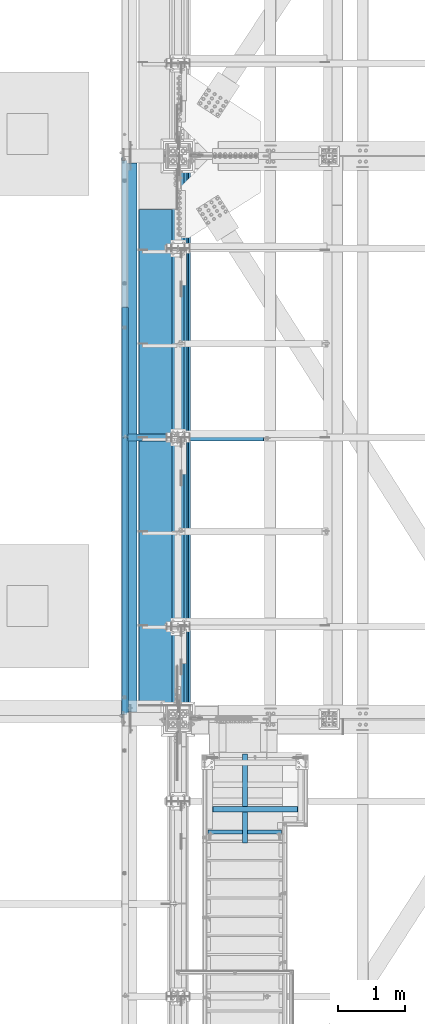
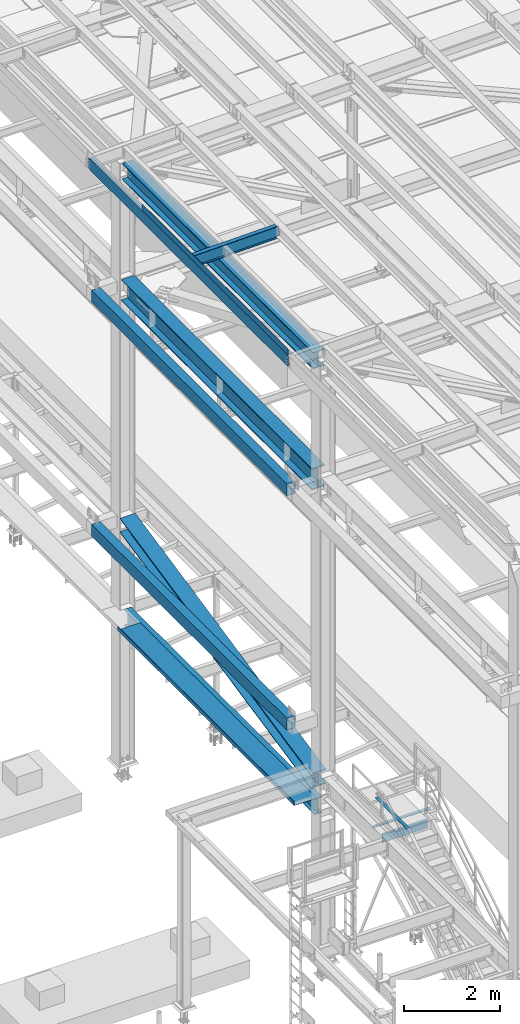
# One storey, part 1804 of 3843: 12 beams, 1 member, 11 elements without a shape of their own.
"""IFC2X3 building model written with IfcOpenShell, lengths in millimetres."""

from ifc_helpers import new_model, si_unit, frame, origin_with_axes, place, context, subcontext, project, spatial, faceted_brep, material, type_object, element, aggregate, save


model = new_model("IFC2X3")

# Units and contexts
model_context = context("Model", 3, precision=1e-05, world=origin_with_axes())
body_context = subcontext(model_context, "Body", "Model", "MODEL_VIEW")
ifc_project = project(units=[si_unit("LENGTHUNIT", "METRE", prefix="MILLI"), si_unit("AREAUNIT", "SQUARE_METRE"), si_unit("VOLUMEUNIT", "CUBIC_METRE"), si_unit("MASSUNIT", "GRAM", prefix="KILO"), si_unit("TIMEUNIT", "SECOND"), si_unit("PLANEANGLEUNIT", "RADIAN"), si_unit("SOLIDANGLEUNIT", "STERADIAN"), si_unit("THERMODYNAMICTEMPERATUREUNIT", "DEGREE_CELSIUS"), si_unit("LUMINOUSINTENSITYUNIT", "LUMEN")], contexts=[model_context])

# Site, building, storey
site_placement = place(None, origin_with_axes())
site = spatial("IfcSite", under=ifc_project, at=site_placement, CompositionType="ELEMENT")
building_placement = place(site_placement, origin_with_axes())
building = spatial("IfcBuilding", under=site, at=building_placement, Name="Undefined", CompositionType="ELEMENT")
storey_placement = place(building_placement, origin_with_axes())
storey = spatial("IfcBuildingStorey", under=building, at=storey_placement, Name="Undefined", CompositionType="ELEMENT", Elevation=0.0)

# Assembly, beams
assembly_1_placement = place(storey_placement, origin_with_axes())
assembly_1 = element("IfcElementAssembly", 1, at=assembly_1_placement, inside=storey, Name="BEAM", AssemblyPlace="NOTDEFINED", PredefinedType="RIGID_FRAME")
ifc_material_1 = material(Name="STEEL/A572-50")
beam_type_1 = type_object("IfcBeamType", Name="C12X20.7", PredefinedType="NOTDEFINED")
beam_1_placement = place(assembly_1_placement, frame((35779.1150555287, 33845.4999999999, 45560.3009647407), z_axis=(-0.0211520980073474, 0.0, 0.999776269347241), x_axis=(0.0, 1.0, 0.0)))
beam_1 = element("IfcBeam", 2, at=beam_1_placement, type_object=beam_type_1, material=ifc_material_1, Name="BEAM", ObjectType="C12X20.7", context=body_context, shape_type="Brep", body=[
    faceted_brep([(15.8750000000582, 30.1624999998166, -126.999999999382), (15.8750003662499, 38.1000000000058, -127.000000023749), (53.975000190796, 38.0999999998094, -126.999999999396), (53.975000190796, 30.1624999998166, -126.999999999382), (58.8350797088351, 38.0999999998094, -127.96672992198), (58.8350797088351, 30.1624999998166, -127.966729921965), (62.955256176996, 38.0999999998021, -130.719743822439), (62.955256176996, 30.1624999998166, -130.719743822439), (65.7082700774772, 38.0999999997948, -134.839920290578), (65.7082700774772, 30.1624999998094, -134.6749274998), (66.6750000000611, 1.14757131086662e-06, -139.699999808552), (66.6750000000611, 38.0999999997948, -139.699999808603), (66.6750000000611, 38.0999999997803, -152.399999999783), (66.6750000000611, -38.1000000000931, -152.39999999971), (66.6750000000611, -38.1000000000931, -146.047459999718), (8289.92500000005, -38.0999999997948, 146.047459999805), (8289.92500000005, -38.0999999997875, 152.399999999798), (66.6750000000611, -38.0999999997875, 152.399999999798), (66.6750000000611, -38.0999999997948, 146.047459999805), (8289.92500000005, 38.1000000000859, 152.399999999725), (66.6750000000611, 38.1000000000859, 152.399999999725), (53.975000190796, 30.1625000000713, 126.999999999265), (53.975000190796, 38.100000000064, 126.999999999258), (15.8750006201954, 38.1000000000058, 126.999999975014), (15.8750000000582, 30.1625000000713, 126.999999999265), (58.8350797088351, 30.1625000000786, 127.966729921849), (58.8350797088351, 38.100000000064, 127.966729921842), (62.955256176996, 30.1625000000786, 130.719743822316), (62.955256176996, 38.1000000000568, 130.719743822301), (65.7082700774772, 30.1625000000786, 134.674927499756), (65.7082700774772, 38.1000000000713, 134.83992029044), (66.6750000000611, 1.1482770787552e-06, 139.699999808494), (66.6750000000611, 38.1000000000713, 139.699999808465), (8290.89172992263, 30.1625000000786, 134.674927499756), (8289.92500000005, 1.1482770787552e-06, 139.699999808494), (8289.92500000005, 38.1000000000713, 139.699999808465), (8290.89172992263, 38.1000000000713, 134.83992029044), (8293.64474382311, 30.1625000000786, 130.719743822316), (8293.64474382311, 38.1000000000568, 130.719743822301), (8297.76492029126, 30.1625000000786, 127.966729921849), (8297.76492029126, 38.100000000064, 127.966729921842), (8302.62499980931, 30.1625000000713, 126.999999999265), (8302.62499980931, 38.100000000064, 126.999999999258), (8340.72500000005, 30.1625000000713, 126.999999999265), (8340.72500000005, 38.100000000064, 126.999999999258), (8340.72500000005, 30.162500000064, 114.299999983516), (8340.72500000005, 30.1624999998385, -116.300000010502), (8340.72500000005, 30.1624999998166, -126.999999999382), (8340.72500000005, 38.0999999998094, -126.999999999396), (8302.62499980931, 30.1624999998166, -126.999999999382), (8302.62499980931, 38.0999999998094, -126.999999999396), (8297.76492029126, 30.1624999998166, -127.966729921965), (8297.76492029126, 38.0999999998094, -127.96672992198), (8293.64474382311, 30.1624999998166, -130.719743822439), (8293.64474382311, 38.0999999998021, -130.719743822439), (8290.89172992263, 30.1624999998094, -134.6749274998), (8290.89172992263, 38.0999999997948, -134.839920290578), (8289.92500000005, 1.14757131086662e-06, -139.699999808552), (8289.92500000005, 38.0999999997948, -139.699999808603), (8289.92500000005, -38.1000000000931, -146.047459999718), (8289.92500000005, -38.1000000000931, -152.39999999971), (8289.92500000005, 38.0999999997803, -152.399999999783), (15.8750000000582, 30.1624999998312, -116.299999999967), (15.8750000000582, 30.1625000000568, 114.299999994066)], [[[0, 1, 2, 3]], [[3, 2, 4, 5]], [[5, 4, 6, 7]], [[7, 6, 8, 9]], [[10, 11, 12, 13, 14]], [[9, 8, 11, 10]], [[15, 16, 17, 18]], [[16, 19, 20, 17]], [[21, 22, 23, 24]], [[25, 26, 22, 21]], [[27, 28, 26, 25]], [[29, 30, 28, 27]], [[31, 32, 30, 29]], [[17, 20, 32, 31, 18]], [[29, 33, 34, 15, 18, 31]], [[16, 15, 34, 35, 19]], [[33, 36, 35, 34]], [[37, 38, 36, 33]], [[39, 40, 38, 37]], [[41, 42, 40, 39]], [[43, 44, 42, 41]], [[44, 43, 45, 46, 47, 48]], [[47, 49, 50, 48]], [[51, 52, 50, 49]], [[53, 54, 52, 51]], [[55, 56, 54, 53]], [[57, 58, 56, 55]], [[59, 60, 61, 58, 57]], [[60, 59, 14, 13]], [[61, 60, 13, 12]], [[6, 4, 2, 1, 23, 22, 26, 28, 30, 32, 20, 19, 35, 36, 38, 40, 42, 44, 48, 50, 52, 54, 56, 58, 61, 12, 11, 8]], [[62, 63, 24, 23, 1, 0]], [[55, 53, 51, 49, 47, 46, 45, 43, 41, 39, 37, 33, 29, 27, 25, 21, 24, 63, 62, 0, 3, 5, 7, 9]], [[59, 57, 55, 9, 10, 14]]]),
])
ifc_material_2 = material(Name="STEEL/A36")
beam_type_2 = type_object("IfcBeamType", PredefinedType="NOTDEFINED")
beam_2_placement = place(assembly_1_placement, frame((35839.3101109824, 36909.3750000001, 45717.1843160671), z_axis=(0.0, -1.0, 0.0), x_axis=(-0.999776270257024, 0.0, -0.0211520550054595)))
beam_2 = element("IfcBeam", 3, at=beam_2_placement, type_object=beam_type_2, material=ifc_material_2, Name="BENT_PLATE", context=body_context, shape_type="Brep", body=[
    faceted_brep([(-3.50355549016967e-07, -3.17499999742722, -3048.00000001723), (3.50421032635495e-07, -3.17500000260043, 3048.00000001724), (3.5035191103816e-07, 3.17499999739084, 3048.00000001724), (-3.50424670614302e-07, 3.17500000256405, -3048.00000001723), (101.599999864371, 3.17499999856227, 3048.00000000522), (101.599998739839, 3.17500000373548, -3048.00000002925), (95.249998765099, -3.17499999632128, -3048.00000002851), (95.2499998896274, -3.17500000149448, 3048.00000000597), (101.600000309205, -161.925000875126, 3047.9999999938), (101.599999608374, -161.925000446165, -3048.00000004067), (95.2500003092064, -161.925000900388, 3047.99999999456), (95.2499996083752, -161.925000471427, -3048.00000003992)], [[[0, 1, 2, 3]], [[3, 2, 4, 5]], [[1, 0, 6, 7]], [[5, 4, 8, 9]], [[4, 2, 1, 7, 10, 8]], [[7, 6, 11, 10]], [[6, 0, 3, 5, 9, 11]], [[10, 11, 9, 8]]]),
])
aggregate(assembly_1, [beam_2, beam_1])

# Assembly, beam
assembly_2_placement = place(storey_placement, origin_with_axes())
assembly_2 = element("IfcElementAssembly", 4, at=assembly_2_placement, inside=storey, Name="STAIR", AssemblyPlace="NOTDEFINED", PredefinedType="RIGID_FRAME")
beam_type_3 = type_object("IfcBeamType", Name="L3X3X1/4", PredefinedType="NOTDEFINED")
beam_3_placement = place(assembly_2_placement, frame((37014.1499998894, 32507.7666666667, 34048.7000000047), z_axis=(0.0, -1.0, 0.0), x_axis=(1.0, 0.0, 0.0)))
beam_3 = element("IfcBeam", 5, at=beam_3_placement, type_object=beam_type_3, material=ifc_material_2, Name="ANGLE", ObjectType="L3X3X1/4", context=body_context, shape_type="Brep", body=[
    faceted_brep([(1339.8500002734, 31.75, 38.0999999999985), (1339.8500002734, 31.75, -31.75), (1339.8500002734, 31.7499999999927, -38.0999999999985), (1333.5000002728, 38.0999999999985, -38.0999999999985), (1333.5000002728, 38.0999999999985, 38.0999999999985), (1397.0000002734, 31.75, -31.75), (1397.0000002734, 31.7499999999927, -38.0999999999985), (1409.7000002734, 19.0499999999884, -31.75), (1409.70000020599, 19.0499999999884, -38.0999999999985), (76.2000000006228, 38.0999999999985, 38.0999999999985), (76.2000000006228, 38.0999999999985, -38.0999999999985), (69.8500000000349, 31.7499999999927, -38.0999999999985), (69.8500000000349, 31.75, -31.75), (69.8500000000349, 31.75, 38.0999999999985), (12.7000000000262, 31.7499999999927, -38.0999999999985), (12.7000000000262, 31.75, -31.75), (0.0, 19.0499999999884, -38.0999999999985), (0.0, 19.0500000000029, -31.75), (0.0, -38.0999999999985, -38.0999999999985), (0.0, -38.0999999999985, -31.75), (1409.70000020599, -38.0999999999985, -38.0999999999985), (1409.70000020599, -38.0999999999985, -31.75)], [[[0, 1, 2, 3, 4]], [[5, 6, 2, 1]], [[7, 8, 6, 5]], [[9, 10, 11, 12, 13]], [[12, 11, 14, 15]], [[15, 14, 16, 17]], [[18, 19, 17, 16]], [[19, 18, 20, 21]], [[1, 12, 15, 17, 19, 21, 7, 5]], [[13, 12, 1, 0]], [[9, 13, 0, 4]], [[10, 9, 4, 3]], [[20, 18, 16, 14, 11, 10, 3, 2, 6, 8]], [[21, 20, 8, 7]]]),
])
aggregate(assembly_2, [beam_3])

# Assembly, member
assembly_3_placement = place(storey_placement, origin_with_axes())
assembly_3 = element("IfcElementAssembly", 6, at=assembly_3_placement, inside=storey, Name="ref.", AssemblyPlace="NOTDEFINED", PredefinedType="RIGID_FRAME")
ifc_material_3 = material(Name="STEEL/Steel_Undefined")
member_type = type_object("IfcMemberType", PredefinedType="NOTDEFINED")
member_placement = place(assembly_3_placement, frame((37566.5999999524, 32009.4314299331, 34134.425), z_axis=(-1.0, 0.0, 0.0), x_axis=(0.0, 1.0, 0.0)))
member = element("IfcMember", 7, at=member_placement, type_object=member_type, material=ifc_material_3, Name="ref.", context=body_context, shape_type="Brep", body=[
    faceted_brep([(0.0, 3.17500000000291, -38.0999999999985), (0.0, 3.17500000000291, 38.0999999999985), (1320.8, 3.17500000000291, 38.0999999999985), (1320.8, 3.17500000000291, -38.0999999999985), (0.0, -3.17500000000291, 38.0999999999985), (1320.8, -3.17500000000291, 38.0999999999985), (0.0, -3.17500000000291, -38.0999999999985), (1320.8, -3.17500000000291, -38.0999999999985)], [[[0, 1, 2, 3]], [[1, 4, 5, 2]], [[4, 6, 7, 5]], [[6, 0, 3, 7]], [[5, 7, 3, 2]], [[6, 4, 1, 0]]]),
])
aggregate(assembly_3, [member])

# Assembly, beam
assembly_4_placement = place(storey_placement, origin_with_axes())
assembly_4 = element("IfcElementAssembly", 8, at=assembly_4_placement, inside=storey, Name="BEAM", AssemblyPlace="NOTDEFINED", PredefinedType="RIGID_FRAME")
beam_type_4 = type_object("IfcBeamType", Name="C8X11.5", PredefinedType="NOTDEFINED")
beam_4_placement = place(assembly_4_placement, frame((38125.3999999478, 32172.275, 33985.2000000051), z_axis=(0.0, 0.0, 1.0), x_axis=(-1.0, 0.0, 0.0)))
beam_4 = element("IfcBeam", 9, at=beam_4_placement, type_object=beam_type_4, material=ifc_material_2, Name="BEAM", ObjectType="C8X11.5", context=body_context, shape_type="Brep", body=[
    faceted_brep([(12.6999999477412, 28.5749999999971, -101.599999999999), (12.6999999477412, 28.5749999999971, 101.599999999999), (1104.90000001137, 28.5749999999971, 101.599999999999), (1104.90000001137, 28.5749999999971, -101.599999999999), (12.6999999477412, -28.5749999999971, 101.599999999999), (1104.90000001137, -28.5749999999971, 101.599999999999), (12.6999999477412, -28.5749999999971, 96.8355949999968), (1104.90000001137, -28.5749999999971, 96.8355949999968), (12.6999999477412, 22.2249999999985, 88.3723150000005), (1104.90000001137, 22.2249999999985, 88.3723150000005), (12.6999999477412, 22.2249999999985, -88.3723150000005), (1104.90000001137, 22.2249999999985, -88.3723150000005), (12.6999999477412, -28.5749999999971, -96.8355949999968), (1104.90000001137, -28.5749999999971, -96.8355949999968), (12.6999999477412, -28.5749999999971, -101.599999999999), (1104.90000001137, -28.5749999999971, -101.599999999999)], [[[0, 1, 2, 3]], [[1, 4, 5, 2]], [[4, 6, 7, 5]], [[6, 8, 9, 7]], [[8, 10, 11, 9]], [[10, 12, 13, 11]], [[12, 14, 15, 13]], [[14, 0, 3, 15]], [[5, 7, 9, 11, 13, 15, 3, 2]], [[14, 12, 10, 8, 6, 4, 1, 0]]]),
])
aggregate(assembly_4, [beam_4])

assembly_5_placement = place(storey_placement, origin_with_axes())
assembly_5 = element("IfcElementAssembly", 10, at=assembly_5_placement, inside=storey, Name="BEAM", AssemblyPlace="NOTDEFINED", PredefinedType="RIGID_FRAME")
ifc_material_4 = material(Name="STEEL/A992")
beam_type_5 = type_object("IfcBeamType", Name="W21X101", PredefinedType="NOTDEFINED")
beam_5_placement = place(assembly_5_placement, frame((36576.0, 33845.5, 42197.3375), z_axis=(0.0, 0.0, 1.0), x_axis=(0.0, 1.0, 0.0)))
beam_5 = element("IfcBeam", 11, at=beam_5_placement, type_object=beam_type_5, material=ifc_material_4, Name="BEAM", ObjectType="W21X101", context=body_context, shape_type="Brep", body=[
    faceted_brep([(8161.33749999999, -155.574999999997, 250.824999999997), (8161.33749999999, -6.34999999999854, 250.824999999997), (8161.33749999999, 6.34999999999854, 250.824999999997), (8161.33749999999, 155.574999999997, 250.824999999997), (8149.42289888391, 155.574999999997, 271.462500000001), (8149.42289888391, -155.574999999997, 271.462500000001), (198.4375, -6.34999999999854, -250.824999999997), (198.4375, -155.574999999997, -250.824999999997), (8158.16250000001, -155.574999999997, -250.824999999997), (8158.16250000001, -6.34999999999854, -250.824999999997), (198.4375, -155.574999999997, -271.462500000001), (8158.16250000001, -155.574999999997, -271.462500000001), (198.4375, 155.574999999997, -271.462500000001), (8158.16250000001, 155.574999999997, -271.462500000001), (198.4375, 155.574999999997, -250.824999999997), (198.4375, 6.34999999999854, -250.824999999997), (8158.16250000001, 6.34999999999854, -250.824999999997), (8158.16250000001, 155.574999999997, -250.824999999997), (198.4375, -6.34999999999854, 250.824999999997), (198.4375, -155.574999999997, 250.824999999997), (198.4375, -155.574999999997, 271.462500000001), (198.4375, 155.574999999997, 271.462500000001), (198.4375, 155.574999999997, 250.824999999997), (198.4375, 6.34999999999854, 250.824999999997), (8161.33749999999, -6.34999999999854, 250.428), (8161.33749999999, 6.34999999999854, 250.428), (8126.41250000001, -6.34999999999854, 250.428), (8126.41250000001, 6.34999999999854, 250.428), (8081.02759456493, -6.34999999999854, 234.406795689014), (8081.02759456493, 6.34999999999854, 234.406795689014), (8076.73823210121, -6.34999999999854, 231.347328818971), (8076.73823210121, 6.34999999999854, 231.347328818971), (8074.73137781811, -6.34999999999854, 226.475829690324), (8074.73137781811, 6.34999999999854, 226.475829690324), (8075.62106119224, -6.34999999999854, 221.282812131351), (8075.62106119224, 6.34999999999854, 221.282812131351), (8079.13506922779, -6.34999999999854, 217.357163726287), (8079.13506922779, 6.34999999999854, 217.357163726287), (8084.19823441855, -6.34999999999854, 215.900000000001), (8084.19823441855, 6.34999999999854, 215.900000000001), (8158.16250000001, -6.34999999999854, 215.900000000001), (8158.16250000001, 6.34999999999854, 215.900000000001)], [[[0, 1, 2, 3, 4, 5]], [[6, 7, 8, 9]], [[7, 10, 11, 8]], [[10, 12, 13, 11]], [[14, 15, 16, 17]], [[12, 14, 17, 13]], [[10, 7, 6, 18, 19, 20, 21, 22, 23, 15, 14, 12]], [[20, 19, 0, 5]], [[21, 20, 5, 4]], [[22, 21, 4, 3]], [[23, 22, 3, 2]], [[24, 25, 2, 1]], [[26, 27, 25, 24]], [[28, 29, 27, 26]], [[30, 31, 29, 28]], [[32, 33, 31, 30]], [[34, 35, 33, 32]], [[36, 37, 35, 34]], [[38, 39, 37, 36]], [[39, 38, 40, 41]], [[15, 23, 2, 25, 27, 29, 31, 33, 35, 37, 39, 41, 16]], [[40, 9, 8, 11, 13, 17, 16, 41]], [[38, 36, 34, 32, 30, 28, 26, 24, 1, 18, 6, 9, 40]], [[19, 18, 1, 0]]]),
])
aggregate(assembly_5, [beam_5])

assembly_6_placement = place(storey_placement, origin_with_axes())
assembly_6 = element("IfcElementAssembly", 12, at=assembly_6_placement, inside=storey, Name="GIRT", AssemblyPlace="NOTDEFINED", PredefinedType="RIGID_FRAME")
ifc_material_5 = material()
beam_type_6 = type_object("IfcBeamType", Name="HSS12X8X3/8", PredefinedType="NOTDEFINED")
beam_6_placement = place(assembly_6_placement, frame((35861.625, 33845.5, 42214.8), z_axis=(0.0, 0.0, 1.0), x_axis=(0.0, 1.0, 0.0)))
beam_6 = element("IfcBeam", 13, at=beam_6_placement, type_object=beam_type_6, material=ifc_material_5, Name="GIRT", ObjectType="HSS12X8X3/8", context=body_context, shape_type="Brep", body=[
    faceted_brep([(8253.41249999999, 101.599999999999, 152.400000000001), (8253.41249999999, 101.599999999999, -152.400000000001), (103.1875, 101.600000000006, -152.400000000001), (103.1875, 101.600000000006, 152.400000000001), (8253.41249999999, -101.599999999999, -152.400000000001), (103.1875, -101.600000000006, -152.400000000001), (8253.41249999999, -101.599999999999, 152.400000000001), (103.1875, -101.600000000006, 152.400000000001), (103.1875, 92.0749999999971, -142.875), (103.1875, 92.0749999999971, 142.875), (103.1875, -92.0749999999971, 142.875), (103.1875, -92.0749999999971, -142.875), (8253.41249999999, -92.0749999999971, 142.875), (8253.41249999999, -92.0749999999971, -142.875), (8253.41249999999, 92.0749999999971, -142.875), (8253.41249999999, 92.0749999999971, 142.875)], [[[0, 1, 2, 3]], [[1, 4, 5, 2]], [[4, 6, 7, 5]], [[6, 0, 3, 7]], [[2, 5, 7, 3], [8, 9, 10, 11]], [[12, 13, 11, 10]], [[13, 14, 8, 11]], [[14, 15, 9, 8]], [[15, 12, 10, 9]], [[1, 0, 6, 4], [14, 13, 12, 15]]]),
])
aggregate(assembly_6, [beam_6])

assembly_7_placement = place(storey_placement, origin_with_axes())
assembly_7 = element("IfcElementAssembly", 14, at=assembly_7_placement, inside=storey, Name="GIRT", AssemblyPlace="NOTDEFINED", PredefinedType="RIGID_FRAME")
beam_7_placement = place(assembly_7_placement, frame((35861.625, 33659.7625, 36252.15), z_axis=(0.0, 0.0, 1.0), x_axis=(0.0, 1.0, 0.0)))
beam_7 = element("IfcBeam", 15, at=beam_7_placement, type_object=beam_type_6, material=ifc_material_5, Name="GIRT", ObjectType="HSS12X8X3/8", context=body_context, shape_type="Brep", body=[
    faceted_brep([(8439.15000000001, 101.599999999999, -152.400000000001), (8439.15000000001, -101.599999999999, -152.400000000001), (288.925000000003, -101.599999999999, -152.400000000001), (288.925000000003, 101.599999999999, -152.400000000001), (8439.15000000001, 101.599999999999, 152.400000000001), (288.925000000003, 101.599999999999, 152.400000000001), (8439.15000000001, -101.599999999999, 152.400000000001), (288.925000000003, -101.599999999999, 152.400000000001), (8439.15000000001, 92.0749999999971, -142.875), (8439.15000000001, -92.0749999999971, -142.875), (8439.15000000001, -92.0749999999971, 142.875), (8439.15000000001, 92.0749999999971, 142.875), (288.925000000003, -92.0749999999971, 142.875), (288.925000000003, 92.0749999999971, 142.875), (288.925000000003, 92.0749999999971, -142.875), (288.925000000003, -92.0749999999971, -142.875)], [[[0, 1, 2, 3]], [[4, 0, 3, 5]], [[6, 4, 5, 7]], [[1, 6, 7, 2]], [[0, 4, 6, 1], [8, 9, 10, 11]], [[11, 10, 12, 13]], [[8, 11, 13, 14]], [[9, 8, 14, 15]], [[10, 9, 15, 12]], [[3, 2, 7, 5], [14, 13, 12, 15]]]),
])
aggregate(assembly_7, [beam_7])

assembly_8_placement = place(storey_placement, origin_with_axes())
assembly_8 = element("IfcElementAssembly", 16, at=assembly_8_placement, inside=storey, Name="BEAM", AssemblyPlace="NOTDEFINED", PredefinedType="RIGID_FRAME")
beam_type_7 = type_object("IfcBeamType", Name="W12X19", PredefinedType="NOTDEFINED")
beam_8_placement = place(assembly_8_placement, frame((35741.0571586919, 38023.7999999999, 45557.9079249889), z_axis=(-0.0211520980073474, 0.0, 0.999776269347241), x_axis=(0.999776270257024, 0.0, 0.0211520550054619)))
beam_8 = element("IfcBeam", 17, at=beam_8_placement, type_object=beam_type_7, material=ifc_material_4, Name="BEAM", ObjectType="W12X19", context=body_context, shape_type="Brep", body=[
    faceted_brep([(20.6374979119428, -3.17500000000291, -128.587500021946), (20.6374979119428, 3.17500000000291, -128.587500021946), (84.1374979491229, 3.17500000000291, -128.587500085479), (84.1374979491229, -3.17500000000291, -128.587500085479), (88.9975774661289, 3.17500000000291, -129.554230012938), (88.9975774661289, -3.17500000000291, -129.554230012938), (93.1177539315104, 3.17500000000291, -132.307243917545), (93.1177539315104, -3.17500000000291, -132.307243917545), (95.8707678278151, 3.17500000000291, -136.427420388471), (95.8707678278151, -3.17500000000291, -136.427420388471), (96.8374977455387, -3.17500000000291, -141.287499907492), (96.8374977455387, 3.17500000000291, -141.287499907492), (96.8374977423518, 3.17500000000291, -144.462499999776), (96.8374977423518, 50.8000000000029, -144.462499999776), (96.8374977328203, 50.8000000000029, -153.987499999792), (96.8374977328203, -50.8000000000029, -153.987499999792), (96.8374977423518, -50.8000000000029, -144.462499999776), (96.8374977423518, -3.17500000000291, -144.462499999776), (2105.36157342605, 50.8000000000029, 144.462500001886), (2105.36157342605, 3.17500000000291, 144.462500001886), (96.8374980314547, 3.17500000000291, 144.462500000489), (96.8374980314547, 50.8000000000029, 144.462500000489), (84.1374982064444, -3.17500000000291, 128.587499915513), (84.1374982064444, 3.17500000000291, 128.587499915513), (20.637499711811, 3.17500000000291, 128.587499979069), (20.637499711811, -3.17500000000291, 128.587499979069), (88.9975777254003, -3.17500000000291, 129.554229833244), (88.9975777254003, 3.17500000000291, 129.554229833244), (93.1177541962679, -3.17500000000291, 132.307243729607), (93.1177541962679, 3.17500000000291, 132.307243729607), (95.8707681008382, -3.17500000000291, 136.427420195025), (95.8707681008382, 3.17500000000291, 136.427420195025), (96.8374980282824, -3.17500000000291, 141.287499712118), (96.8374980282824, 3.17500000000291, 141.287499712118), (2105.36157342604, -50.8000000000029, 153.987500001873), (2105.36157342604, 50.8000000000029, 153.987500001873), (96.8374980410008, 50.8000000000029, 153.987500000498), (96.8374980410154, -50.8000000000029, 153.987499285155), (2105.36157342605, -50.8000000000029, 144.462500001886), (96.8374980314547, -50.8000000000029, 144.462500000489), (2105.36157342605, -3.17500000000291, 144.462500001886), (96.8374980314547, -3.17500000000291, 144.462500000489), (2105.36157342605, -3.17500000000291, 141.28749984406), (2105.36157342605, 3.17500000000291, 141.28749984406), (2106.32830334864, -3.17500000000291, 136.427420326036), (2106.32830334864, 3.17500000000291, 136.427420326036), (2109.08131724911, -3.17500000000291, 132.307243857911), (2109.08131724911, 3.17500000000291, 132.307243857911), (2113.20149371724, -3.17500000000291, 129.554229957444), (2113.20149371724, 3.17500000000291, 129.554229957444), (2118.06157323526, -3.17500000000291, 128.587500034868), (2118.06157323526, 3.17500000000291, 128.587500034868), (2187.91061593533, -3.17500000000291, 128.587500034926), (2187.9107285587, 3.17500000000291, 128.587500034926), (2187.91061584618, -3.17500000000291, 115.887499672281), (2187.91061422746, -3.17500000000291, -114.7125003291), (2187.91061413007, -3.17500000000291, -128.587499964618), (2187.91072675344, 3.17500000000291, -128.587499964611), (2118.06157323984, -3.17500000000291, -128.587499964677), (2118.06157323984, 3.17500000000291, -128.587499964677), (2113.20149372181, -3.17500000000291, -129.554229887261), (2113.20149372181, 3.17500000000291, -129.554229887261), (2109.08131725368, -3.17500000000291, -132.307243787734), (2109.08131725368, 3.17500000000291, -132.307243787734), (2106.32830335322, -3.17500000000291, -136.427420255866), (2106.32830335322, 3.17500000000291, -136.427420255866), (2105.36157343064, -3.17500000000291, -141.287499773891), (2105.36157343064, 3.17500000000291, -141.287499773891), (2105.36157343065, -3.17500000000291, -144.462499997651), (2105.36157343065, -50.8000000000029, -144.462499997651), (2105.36157343067, -50.8000000000029, -153.987499997631), (2105.36157343067, 50.8000000000029, -153.987499997631), (2105.36157343065, 50.8000000000029, -144.462499997651), (2105.36157343065, 3.17500000000291, -144.462499997651), (20.6374980090477, 3.17500000000291, -114.712499752241), (20.6374996229279, 3.17500000000291, 115.88750024372)], [[[0, 1, 2, 3]], [[3, 2, 4, 5]], [[5, 4, 6, 7]], [[7, 6, 8, 9]], [[10, 11, 12, 13, 14, 15, 16, 17]], [[9, 8, 11, 10]], [[18, 19, 20, 21]], [[22, 23, 24, 25]], [[26, 27, 23, 22]], [[28, 29, 27, 26]], [[30, 31, 29, 28]], [[32, 33, 31, 30]], [[34, 35, 36, 37]], [[38, 34, 37, 39]], [[40, 38, 39, 41]], [[37, 36, 21, 20, 33, 32, 41, 39]], [[35, 18, 21, 36]], [[34, 38, 40, 42, 43, 19, 18, 35]], [[44, 45, 43, 42]], [[46, 47, 45, 44]], [[48, 49, 47, 46]], [[50, 51, 49, 48]], [[52, 53, 51, 50]], [[53, 52, 54, 55, 56, 57]], [[56, 58, 59, 57]], [[60, 61, 59, 58]], [[62, 63, 61, 60]], [[64, 65, 63, 62]], [[66, 67, 65, 64]], [[68, 69, 70, 71, 72, 73, 67, 66]], [[69, 68, 17, 16]], [[70, 69, 16, 15]], [[71, 70, 15, 14]], [[72, 71, 14, 13]], [[73, 72, 13, 12]], [[6, 4, 2, 1, 74, 75, 24, 23, 27, 29, 31, 33, 20, 19, 43, 45, 47, 49, 51, 53, 57, 59, 61, 63, 65, 67, 73, 12, 11, 8]], [[25, 24, 75, 74, 1, 0]], [[68, 66, 64, 62, 60, 58, 56, 55, 54, 52, 50, 48, 46, 44, 42, 40, 41, 32, 30, 28, 26, 22, 25, 0, 3, 5, 7, 9, 10, 17]]]),
])
aggregate(assembly_8, [beam_8])

assembly_9_placement = place(storey_placement, origin_with_axes())
assembly_9 = element("IfcElementAssembly", 18, at=assembly_9_placement, inside=storey, Name="BEAM", AssemblyPlace="NOTDEFINED", PredefinedType="RIGID_FRAME")
beam_type_8 = type_object("IfcBeamType", PredefinedType="NOTDEFINED")
beam_9_placement = place(assembly_9_placement, frame((36537.9000000002, 37726.9375, 34039.175), z_axis=(0.0, -1.0, 0.0), x_axis=(-1.0, 0.0, 0.0)))
beam_9 = element("IfcBeam", 19, at=beam_9_placement, type_object=beam_type_8, material=ifc_material_2, Name="BENT_PLATE", context=body_context, shape_type="Brep", body=[
    faceted_brep([(0.0, -3.17500000000291, -3683.0), (0.0, -3.17500000000291, 3683.0), (0.0, 3.17500000000291, 3683.0), (0.0, 3.17500000000291, -3683.0), (546.099973958531, 3.17500000000291, 3683.0), (546.099973958531, 3.17500000000291, -3683.0), (539.749975586135, -3.17500000000291, -3683.0), (539.749975586135, -3.17500000000291, 3683.0), (546.100000000202, -98.4249983721893, 3683.0), (546.100000000202, -98.4249983721893, -3683.0), (539.750000000196, -98.4249999997919, 3683.0), (539.750000000196, -98.4249999997919, -3683.0)], [[[0, 1, 2, 3]], [[3, 2, 4, 5]], [[1, 0, 6, 7]], [[5, 4, 8, 9]], [[4, 2, 1, 7, 10, 8]], [[7, 6, 11, 10]], [[6, 0, 3, 5, 9, 11]], [[10, 11, 9, 8]]]),
])

assembly_10_placement = place(storey_placement, origin_with_axes())
assembly_10 = element("IfcElementAssembly", 20, at=assembly_10_placement, inside=storey, Name="BEAM", AssemblyPlace="NOTDEFINED", PredefinedType="RIGID_FRAME")
beam_type_9 = type_object("IfcBeamType", Name="W16X67", PredefinedType="NOTDEFINED")
beam_10_placement = place(assembly_10_placement, frame((36576.0000000114, 33845.5, 45210.4125000001), z_axis=(0.0, 0.0, 1.0), x_axis=(0.0, 1.0, 0.0)))
beam_10 = element("IfcBeam", 21, at=beam_10_placement, type_object=beam_type_9, material=ifc_material_4, Name="BEAM", ObjectType="W16X67", context=body_context, shape_type="Brep", body=[
    faceted_brep([(198.437499999989, -130.175000000003, -207.962500000001), (198.437499999989, 130.175000000003, -207.962500000001), (8158.16249999999, 130.175000000003, -207.962500000001), (8158.16249999999, -130.175000000003, -207.962500000001), (198.437499999989, -130.175000000003, -190.5), (198.437499999989, -4.76249999999709, -190.5), (198.4375, -4.76249999999709, -142.027499865253), (198.4375, -4.76249999999709, 176.952500133215), (198.437499999989, -4.76249999999709, 190.5), (198.437499999989, -130.175000000003, 190.5), (198.437499999989, -130.175000000003, 207.962500000001), (198.437499999989, 130.175000000003, 207.962500000001), (198.437499999989, 130.175000000003, 190.5), (198.437499999989, 4.76249999999709, 190.5), (198.437499999989, 4.76249999999709, -190.5), (198.437499999989, 130.175000000003, -190.5), (8158.16249999999, -130.175000000003, -190.5), (8158.16249999999, -4.76249999999709, -190.5), (8158.16249999999, -4.76249999999709, -142.02750001238), (8158.16249999999, -4.76249999999709, 176.952499987616), (8158.16249999999, -4.76249999999709, 190.5), (8158.16249999999, -130.175000000003, 190.5), (8158.16249999999, -130.175000000003, 207.962500000001), (8158.16249999999, 130.175000000003, 207.962500000001), (8158.16249999999, 130.175000000003, 190.5), (8158.16249999999, 4.76249999999709, 190.5), (8158.16249999999, 4.76249999999709, -190.5), (8158.16249999999, 130.175000000003, -190.5)], [[[0, 1, 2, 3]], [[0, 4, 5, 6, 7, 8, 9, 10, 11, 12, 13, 14, 15, 1]], [[5, 4, 16, 17]], [[8, 7, 6, 5, 17, 18, 19, 20]], [[9, 8, 20, 21]], [[10, 9, 21, 22]], [[11, 10, 22, 23]], [[12, 11, 23, 24]], [[13, 12, 24, 25]], [[14, 13, 25, 26]], [[15, 14, 26, 27]], [[1, 15, 27, 2]], [[26, 25, 24, 23, 22, 21, 20, 19, 18, 17, 16, 3, 2, 27]], [[4, 0, 3, 16]]]),
])
aggregate(assembly_10, [beam_10])

# Beam
beam_type_10 = type_object("IfcBeamType", Name="W16X40", PredefinedType="NOTDEFINED")
beam_11_placement = place(assembly_9_placement, frame((36576.0, 33845.5, 33832.8), z_axis=(0.0, 0.0, 1.0), x_axis=(0.0, 1.0, 0.0)))
beam_11 = element("IfcBeam", 22, at=beam_11_placement, type_object=beam_type_10, material=ifc_material_4, Name="BEAM", ObjectType="W16X40", context=body_context, shape_type="Brep", body=[
    faceted_brep([(198.4375, -88.9000000000015, -203.199999999997), (198.4375, 88.9000000000015, -203.199999999997), (8158.16249999999, 88.9000000000015, -203.199999999997), (8158.16249999999, -88.9000000000015, -203.199999999997), (198.4375, -88.9000000000015, -190.5), (198.4375, -3.96875, -190.5), (198.4375, -3.96875, -140.440014546963), (198.4375, -3.96875, 165.839999999997), (198.4375, -3.96875, 190.5), (198.4375, -88.9000000000015, 190.5), (198.4375, -88.9000000000015, 203.199999999997), (198.4375, 88.9000000000015, 203.199999999997), (198.4375, 88.9000000000015, 190.5), (198.4375, 3.96875, 190.5), (198.4375, 3.96875, -190.5), (198.4375, 88.9000000000015, -190.5), (8158.16249999999, -88.9000000000015, -190.5), (8158.16249999999, -3.96875, -190.5), (8158.16249999999, -3.96875, -140.440014546963), (8158.16249999999, -3.96875, 165.839999999997), (8158.16249999999, -3.96875, 190.5), (8158.16249999999, -88.9000000000015, 190.5), (8158.16249999999, -88.9000000000015, 203.199999999997), (8158.16249999999, 88.9000000000015, 203.199999999997), (8158.16249999999, 88.9000000000015, 190.5), (8158.16249999999, 3.96875, 190.5), (8158.16249999999, 3.96875, -190.5), (8158.16249999999, 88.9000000000015, -190.5)], [[[0, 1, 2, 3]], [[0, 4, 5, 6, 7, 8, 9, 10, 11, 12, 13, 14, 15, 1]], [[5, 4, 16, 17]], [[8, 7, 6, 5, 17, 18, 19, 20]], [[9, 8, 20, 21]], [[10, 9, 21, 22]], [[11, 10, 22, 23]], [[12, 11, 23, 24]], [[13, 12, 24, 25]], [[14, 13, 25, 26]], [[15, 14, 26, 27]], [[1, 15, 27, 2]], [[26, 25, 24, 23, 22, 21, 20, 19, 18, 17, 16, 3, 2, 27]], [[4, 0, 3, 16]]]),
])

aggregate(assembly_9, [beam_9, beam_11])

# Assembly, beam
assembly_11_placement = place(storey_placement, origin_with_axes())
assembly_11 = element("IfcElementAssembly", 23, at=assembly_11_placement, inside=storey, Name="BEAM", AssemblyPlace="NOTDEFINED", PredefinedType="RIGID_FRAME")
beam_type_11 = type_object("IfcBeamType", Name="W14X90", PredefinedType="NOTDEFINED")
beam_12_placement = place(assembly_11_placement, frame((36576.0, 33882.5015391856, 34484.3927658224), z_axis=(0.0, -0.208107644017044, 0.978105929080115), x_axis=(0.0, 0.978105929080112, 0.208107644017058)))
beam_12 = element("IfcBeam", 24, at=beam_12_placement, type_object=beam_type_11, material=ifc_material_4, Name="BEAM", ObjectType="W14X90", context=body_context, shape_type="Brep", body=[
    faceted_brep([(127.219780607789, 184.150000000001, -177.800000000825), (130.935206131355, 184.150000000001, -160.33750000078), (8268.83189347423, 184.150000000001, -160.337500019694), (8265.11646795066, 184.150000000001, -177.800000019739), (130.935206131355, 5.55625000000146, -160.33750000078), (8268.83189347423, 5.55625000000146, -160.337500019694), (199.163929382317, 5.55625000000146, 160.337500000023), (8337.06061672519, 5.55625000000146, 160.337499981117), (199.163929382317, 184.150000000001, 160.337500000023), (8337.06061672519, 184.150000000001, 160.337499981117), (202.879354905883, 184.150000000001, 177.800000000061), (8340.77604224876, 184.150000000001, 177.799999981162), (202.879354905883, -184.150000000001, 177.800000000061), (8340.77604224876, -184.150000000001, 177.799999981162), (199.163929382317, -184.150000000001, 160.337500000023), (8337.06061672519, -184.150000000001, 160.337499981117), (199.163929382317, -5.55625000000146, 160.337500000023), (8337.06061672519, -5.55625000000146, 160.337499981117), (130.935206131355, -5.55625000000146, -160.33750000078), (8268.83189347423, -5.55625000000146, -160.337500019694), (130.935206131355, -184.150000000001, -160.33750000078), (8268.83189347423, -184.150000000001, -160.337500019694), (127.219780607789, -184.150000000001, -177.800000000825), (8265.11646795066, -184.150000000001, -177.800000019739)], [[[0, 1, 2, 3]], [[1, 4, 5, 2]], [[4, 6, 7, 5]], [[6, 8, 9, 7]], [[8, 10, 11, 9]], [[10, 12, 13, 11]], [[12, 14, 15, 13]], [[14, 16, 17, 15]], [[16, 18, 19, 17]], [[18, 20, 21, 19]], [[20, 22, 23, 21]], [[22, 0, 3, 23]], [[5, 7, 9, 11, 13, 15, 17, 19, 21, 23, 3, 2]], [[22, 20, 18, 16, 14, 12, 10, 8, 6, 4, 1, 0]]]),
])
aggregate(assembly_11, [beam_12])

save(model, "model.ifc")
